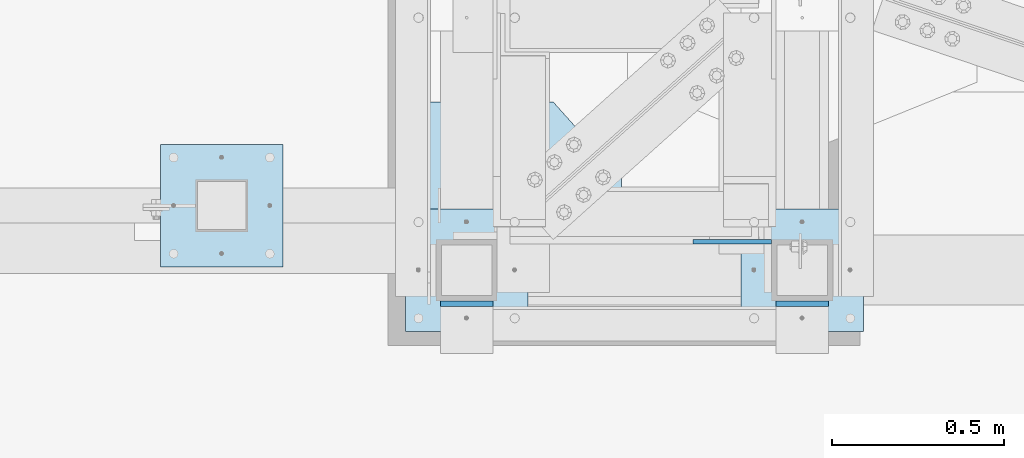
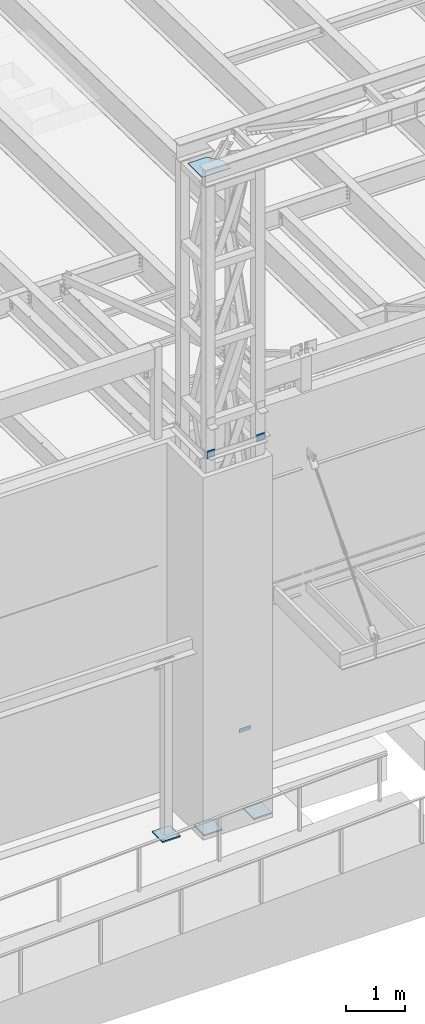
# One storey, part 1443 of 1763: 7 plates, 3 elements without a shape of their own.
"""IFC2X3 building model written with IfcOpenShell, lengths in millimetres."""

from ifc_helpers import new_model, si_unit, frame, origin_with_axes, place, context, subcontext, project, spatial, faceted_brep, material, type_object, element, aggregate, save


model = new_model("IFC2X3")

# Units and contexts
model_context = context("Model", 3, precision=1e-05, world=origin_with_axes())
body_context = subcontext(model_context, "Body", "Model", "MODEL_VIEW")
ifc_project = project(units=[si_unit("LENGTHUNIT", "METRE", prefix="MILLI"), si_unit("AREAUNIT", "SQUARE_METRE"), si_unit("VOLUMEUNIT", "CUBIC_METRE"), si_unit("MASSUNIT", "GRAM", prefix="KILO"), si_unit("TIMEUNIT", "SECOND"), si_unit("PLANEANGLEUNIT", "RADIAN"), si_unit("SOLIDANGLEUNIT", "STERADIAN"), si_unit("THERMODYNAMICTEMPERATUREUNIT", "DEGREE_CELSIUS"), si_unit("LUMINOUSINTENSITYUNIT", "LUMEN")], contexts=[model_context])

# Site, building, storey
site_placement = place(None, origin_with_axes())
site = spatial("IfcSite", under=ifc_project, at=site_placement, CompositionType="ELEMENT")
building_placement = place(site_placement, origin_with_axes())
building = spatial("IfcBuilding", under=site, at=building_placement, Name="Undefined", CompositionType="ELEMENT")
storey_placement = place(building_placement, origin_with_axes())
storey = spatial("IfcBuildingStorey", under=building, at=storey_placement, Name="Undefined", CompositionType="ELEMENT", Elevation=0.0)

# Assembly, plates
assembly_1_placement = place(storey_placement, origin_with_axes())
assembly_1 = element("IfcElementAssembly", 1, at=assembly_1_placement, inside=storey, Name="FRAME", AssemblyPlace="NOTDEFINED", PredefinedType="RIGID_FRAME")
ifc_material = material(Name="STEEL/A36")
plate_type_1 = type_object("IfcPlateType", PredefinedType="NOTDEFINED")
plate_1_placement = place(assembly_1_placement, frame((-63528.0024298068, -15370.1773151463, 6845.29999694824), z_axis=(0.99999999999718, 2.37500000002911e-06, 0.0), x_axis=(0.0, 0.0, -1.0)))
plate_1 = element("IfcPlate", 2, at=plate_1_placement, type_object=plate_type_1, material=ifc_material, Name="PLATE", context=body_context, shape_type="Brep", body=[
    faceted_brep([(0.0, -6.34999999999491, 1.45519152283669e-11), (0.0, -6.35000000001855, 228.600006104178), (0.0, 6.34999999996944, 228.600006104134), (0.0, 6.34999999999491, -2.91038304567337e-11), (76.1999969482422, -6.35000000001855, 228.600006104178), (76.1999969482422, 6.34999999996944, 228.600006104134), (76.1999969482422, -6.34999999999491, 1.45519152283669e-11), (76.1999969482422, 6.34999999999491, -2.91038304567337e-11)], [[[0, 1, 2, 3]], [[1, 4, 5, 2]], [[4, 6, 7, 5]], [[6, 0, 3, 7]], [[5, 7, 3, 2]], [[6, 4, 1, 0]]]),
])
plate_type_2 = type_object("IfcPlateType", PredefinedType="NOTDEFINED")
plate_2_placement = place(assembly_1_placement, frame((-63388.3025957005, -15274.9273151462, 5080.0), z_axis=(1.0, 0.0, 0.0), x_axis=(0.0, -1.0, 0.0)))
plate_2 = element("IfcPlate", 3, at=plate_2_placement, type_object=plate_type_2, material=ifc_material, Name="PLATE", context=body_context, shape_type="Brep", body=[
    faceted_brep([(0.0, -12.6999999999971, -1.81898940354586e-12), (0.0, -12.6999999999998, 355.600006103516), (0.0, 12.6999999999998, 355.600006103516), (0.0, 12.6999999999971, -1.81898940354586e-12), (355.600006103516, -12.6999999999998, 355.600006103516), (355.600006103516, 12.6999999999998, 355.600006103516), (355.600006103516, -12.6999999999998, 0.0), (355.600006103516, 12.6999999999998, 0.0)], [[[0, 1, 2, 3]], [[1, 4, 5, 2]], [[4, 6, 7, 5]], [[6, 0, 3, 7]], [[5, 7, 3, 2]], [[6, 4, 1, 0]]]),
])
plate_3_placement = place(assembly_1_placement, frame((-64363.0277910131, -15274.9273151462, 5080.0), z_axis=(1.0, 0.0, 0.0), x_axis=(0.0, -1.0, 0.0)))
plate_3 = element("IfcPlate", 4, at=plate_3_placement, type_object=plate_type_2, material=ifc_material, Name="PLATE", context=body_context, shape_type="Brep", body=[
    faceted_brep([(0.0, -12.6999999999971, -1.81898940354586e-12), (0.0, -12.6999999999998, 355.600006103516), (0.0, 12.6999999999998, 355.600006103516), (0.0, 12.6999999999971, -1.81898940354586e-12), (355.600006103516, -12.6999999999998, 355.600006103516), (355.600006103516, 12.6999999999998, 355.600006103516), (355.600006103516, -12.6999999999998, 0.0), (355.600006103516, 12.6999999999998, 0.0)], [[[0, 1, 2, 3]], [[1, 4, 5, 2]], [[4, 6, 7, 5]], [[6, 0, 3, 7]], [[5, 7, 3, 2]], [[6, 4, 1, 0]]]),
])

# Assembly, plate
assembly_2_placement = place(storey_placement, origin_with_axes())
assembly_2 = element("IfcElementAssembly", 5, at=assembly_2_placement, inside=storey, Name="COLUMN", AssemblyPlace="NOTDEFINED", PredefinedType="RIGID_FRAME")
plate_4_placement = place(assembly_2_placement, frame((-65074.238056465, -15087.6000613784, 5080.0), z_axis=(1.0, 0.0, 0.0), x_axis=(0.0, -1.0, 0.0)))
plate_4 = element("IfcPlate", 6, at=plate_4_placement, type_object=plate_type_2, material=ifc_material, Name="PLATE", context=body_context, shape_type="Brep", body=[
    faceted_brep([(0.0, -12.6999999999971, -1.81898940354586e-12), (0.0, -12.6999999999998, 355.600006103516), (0.0, 12.6999999999998, 355.600006103516), (0.0, 12.6999999999971, -1.81898940354586e-12), (355.600006103516, -12.6999999999998, 355.600006103516), (355.600006103516, 12.6999999999998, 355.600006103516), (355.600006103516, -12.6999999999998, 0.0), (355.600006103516, 12.6999999999998, 0.0)], [[[0, 1, 2, 3]], [[1, 4, 5, 2]], [[4, 6, 7, 5]], [[6, 0, 3, 7]], [[5, 7, 3, 2]], [[6, 4, 1, 0]]]),
])
aggregate(assembly_2, [plate_4])

# Plate
plate_type_3 = type_object("IfcPlateType", PredefinedType="NOTDEFINED")
plate_5_placement = place(assembly_1_placement, frame((-63134.3025957005, -15549.5649208798, 12979.4), z_axis=(0.0, 0.0, -1.0), x_axis=(-1.0, 0.0, 0.0)))
plate_5 = element("IfcPlate", 7, at=plate_5_placement, type_object=plate_type_3, material=ifc_material, Name="PLATE", context=body_context, shape_type="Brep", body=[
    faceted_brep([(-7.27595761418343e-12, -7.9375, 0.0), (7.27595761418343e-12, -7.9375, 152.399993896484), (7.27595761418343e-12, 7.9375, 152.399993896484), (-7.27595761418343e-12, 7.9375, 0.0), (152.399993896484, -7.9375, 152.399993896484), (152.399993896484, 7.9375, 152.399993896484), (152.399993896484, -7.9375, -1.81898940354586e-12), (152.399993896484, 7.9375, -1.81898940354586e-12)], [[[0, 1, 2, 3]], [[1, 4, 5, 2]], [[4, 6, 7, 5]], [[6, 0, 3, 7]], [[5, 7, 3, 2]], [[6, 4, 1, 0]]]),
])

plate_6_placement = place(assembly_1_placement, frame((-64261.4277910131, -15549.5649208798, 12827.0), z_axis=(1.0, 0.0, 0.0), x_axis=(0.0, 0.0, 1.0)))
plate_6 = element("IfcPlate", 8, at=plate_6_placement, type_object=plate_type_3, material=ifc_material, Name="PLATE", context=body_context, shape_type="Brep", body=[
    faceted_brep([(-7.27595761418343e-12, -7.9375, 0.0), (7.27595761418343e-12, -7.9375, 152.399993896484), (7.27595761418343e-12, 7.9375, 152.399993896484), (-7.27595761418343e-12, 7.9375, 0.0), (152.399993896484, -7.9375, 152.399993896484), (152.399993896484, 7.9375, 152.399993896484), (152.399993896484, -7.9375, -1.81898940354586e-12), (152.399993896484, 7.9375, -1.81898940354586e-12)], [[[0, 1, 2, 3]], [[1, 4, 5, 2]], [[4, 6, 7, 5]], [[6, 0, 3, 7]], [[5, 7, 3, 2]], [[6, 4, 1, 0]]]),
])

aggregate(assembly_1, [plate_1, plate_5, plate_6, plate_2, plate_3])

# Assembly, plate
assembly_3_placement = place(storey_placement, origin_with_axes())
assembly_3 = element("IfcElementAssembly", 9, at=assembly_3_placement, inside=storey, Name="BEAM", AssemblyPlace="NOTDEFINED", PredefinedType="RIGID_FRAME")
plate_type_4 = type_object("IfcPlateType", PredefinedType="NOTDEFINED")
plate_7_placement = place(assembly_3_placement, frame((-64299.5277903417, -15447.9647094127, 18616.6125), z_axis=(0.0, 1.0, 0.0), x_axis=(1.0, 0.0, 0.0)))
plate_7 = element("IfcPlate", 10, at=plate_7_placement, type_object=plate_type_4, material=ifc_material, Name="PLATE", context=body_context, shape_type="Brep", body=[
    faceted_brep([(0.0, -4.76249999999982, 0.0), (-2.89212766801938e-06, -4.76250000000073, 483.159637451172), (-2.89212766801938e-06, 4.76250000000073, 483.159637451172), (0.0, 4.76249999999982, 0.0), (366.449584962225, -4.76250000000073, 483.159637450863), (366.449584962225, 4.76250000000073, 483.159637450863), (564.478271485066, -4.76250000000073, 262.082977294443), (564.478271485066, 4.76250000000073, 262.082977294443), (564.478271484375, -4.76250000000073, -4.38376446254551e-10), (564.478271484375, 4.76250000000073, -4.38376446254551e-10)], [[[0, 1, 2, 3]], [[1, 4, 5, 2]], [[4, 6, 7, 5]], [[6, 8, 9, 7]], [[8, 0, 3, 9]], [[5, 7, 9, 3, 2]], [[8, 6, 4, 1, 0]]]),
])
aggregate(assembly_3, [plate_7])

save(model, "model.ifc")
